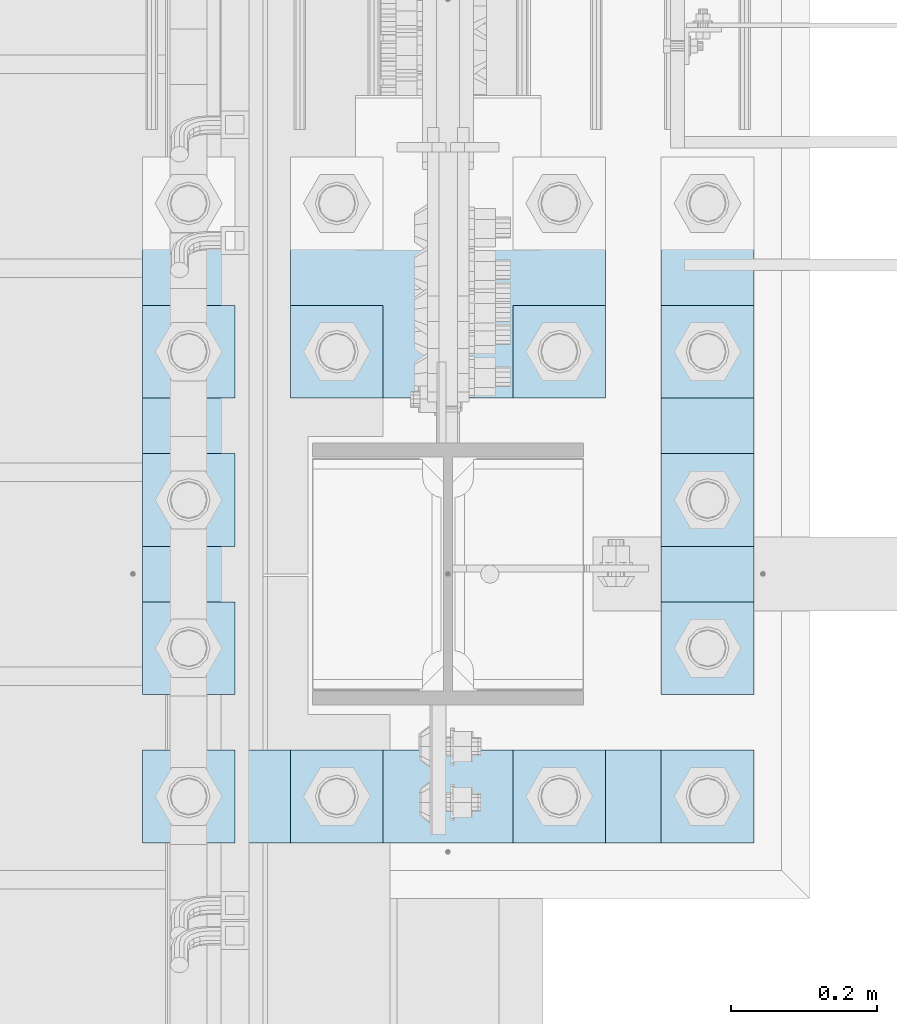
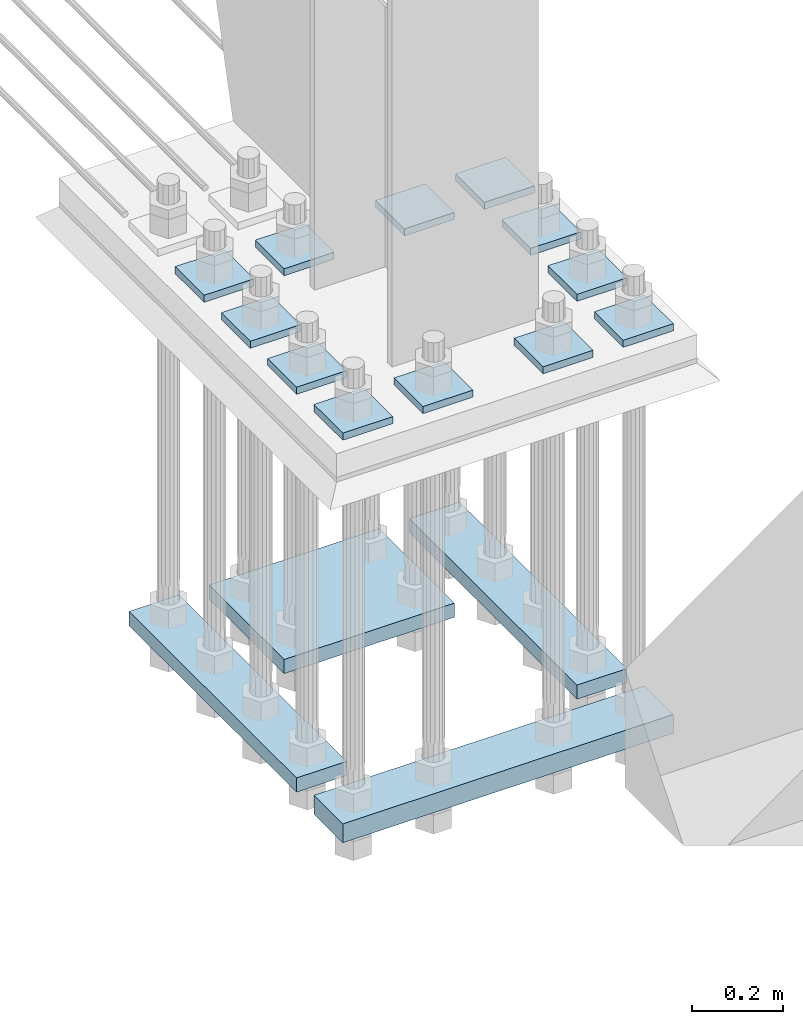
# One storey, part 3121 of 3843: 16 plates, 1 element without a shape of its own.
"""IFC2X3 building model written with IfcOpenShell, lengths in millimetres."""

from ifc_helpers import new_model, si_unit, frame, origin_with_axes, place, context, subcontext, project, spatial, faceted_brep, material, type_object, element, aggregate, save


model = new_model("IFC2X3")

# Units and contexts
model_context = context("Model", 3, precision=1e-05, world=origin_with_axes())
body_context = subcontext(model_context, "Body", "Model", "MODEL_VIEW")
ifc_project = project(units=[si_unit("LENGTHUNIT", "METRE", prefix="MILLI"), si_unit("AREAUNIT", "SQUARE_METRE"), si_unit("VOLUMEUNIT", "CUBIC_METRE"), si_unit("MASSUNIT", "GRAM", prefix="KILO"), si_unit("TIMEUNIT", "SECOND"), si_unit("PLANEANGLEUNIT", "RADIAN"), si_unit("SOLIDANGLEUNIT", "STERADIAN"), si_unit("THERMODYNAMICTEMPERATUREUNIT", "DEGREE_CELSIUS"), si_unit("LUMINOUSINTENSITYUNIT", "LUMEN")], contexts=[model_context])

# Site, building, storey
site_placement = place(None, origin_with_axes())
site = spatial("IfcSite", under=ifc_project, at=site_placement, CompositionType="ELEMENT")
building_placement = place(site_placement, origin_with_axes())
building = spatial("IfcBuilding", under=site, at=building_placement, Name="Undefined", CompositionType="ELEMENT")
storey_placement = place(building_placement, origin_with_axes())
storey = spatial("IfcBuildingStorey", under=building, at=storey_placement, Name="Undefined", CompositionType="ELEMENT", Elevation=0.0)

# Assembly, plates
assembly_placement = place(storey_placement, origin_with_axes())
assembly = element("IfcElementAssembly", 1, at=assembly_placement, inside=storey, Name="TEMPLATE", AssemblyPlace="NOTDEFINED", PredefinedType="RIGID_FRAME")
ifc_material = material(Name="STEEL/A572-50")
plate_type_1 = type_object("IfcPlateType", PredefinedType="NOTDEFINED")
plate_1_placement = place(assembly_placement, frame((55638.7, 20066.0, 29689.425), z_axis=(-1.0, 0.0, 0.0), x_axis=(0.0, -1.0, 0.0)))
plate_1 = element("IfcPlate", 2, at=plate_1_placement, type_object=plate_type_1, material=ifc_material, Name="Washer Plate", context=body_context, shape_type="Brep", body=[
    faceted_brep([(0.0, -9.52500000000146, 0.0), (0.0, -9.52499999999418, 127.0), (0.0, 9.52499999999418, 127.0), (0.0, 9.52500000000146, 0.0), (127.0, -9.52500000000146, 127.0), (127.0, 9.52500000000146, 127.0), (127.0, -9.52500000000146, 0.0), (127.0, 9.52500000000146, 0.0)], [[[0, 1, 2, 3]], [[1, 4, 5, 2]], [[4, 6, 7, 5]], [[6, 0, 3, 7]], [[5, 7, 3, 2]], [[6, 4, 1, 0]]]),
])
plate_2_placement = place(assembly_placement, frame((55841.9, 20066.0, 29689.425), z_axis=(-1.0, 0.0, 0.0), x_axis=(0.0, -1.0, 0.0)))
plate_2 = element("IfcPlate", 3, at=plate_2_placement, type_object=plate_type_1, material=ifc_material, Name="Washer Plate", context=body_context, shape_type="Brep", body=[
    faceted_brep([(0.0, -9.52500000000146, 0.0), (0.0, -9.52499999999418, 127.0), (0.0, 9.52499999999418, 127.0), (0.0, 9.52500000000146, 0.0), (127.0, -9.52500000000146, 127.0), (127.0, 9.52500000000146, 127.0), (127.0, -9.52500000000146, 0.0), (127.0, 9.52500000000146, 0.0)], [[[0, 1, 2, 3]], [[1, 4, 5, 2]], [[4, 6, 7, 5]], [[6, 0, 3, 7]], [[5, 7, 3, 2]], [[6, 4, 1, 0]]]),
])
plate_3_placement = place(assembly_placement, frame((56146.7, 20066.0, 29689.425), z_axis=(-1.0, 0.0, 0.0), x_axis=(0.0, -1.0, 0.0)))
plate_3 = element("IfcPlate", 4, at=plate_3_placement, type_object=plate_type_1, material=ifc_material, Name="Washer Plate", context=body_context, shape_type="Brep", body=[
    faceted_brep([(0.0, -9.52500000000146, 0.0), (0.0, -9.52499999999418, 127.0), (0.0, 9.52499999999418, 127.0), (0.0, 9.52500000000146, 0.0), (127.0, -9.52500000000146, 127.0), (127.0, 9.52500000000146, 127.0), (127.0, -9.52500000000146, 0.0), (127.0, 9.52500000000146, 0.0)], [[[0, 1, 2, 3]], [[1, 4, 5, 2]], [[4, 6, 7, 5]], [[6, 0, 3, 7]], [[5, 7, 3, 2]], [[6, 4, 1, 0]]]),
])
plate_4_placement = place(assembly_placement, frame((56349.9, 20066.0, 29689.425), z_axis=(-1.0, 0.0, 0.0), x_axis=(0.0, -1.0, 0.0)))
plate_4 = element("IfcPlate", 5, at=plate_4_placement, type_object=plate_type_1, material=ifc_material, Name="Washer Plate", context=body_context, shape_type="Brep", body=[
    faceted_brep([(0.0, -9.52500000000146, 0.0), (0.0, -9.52499999999418, 127.0), (0.0, 9.52499999999418, 127.0), (0.0, 9.52500000000146, 0.0), (127.0, -9.52500000000146, 127.0), (127.0, 9.52500000000146, 127.0), (127.0, -9.52500000000146, 0.0), (127.0, 9.52500000000146, 0.0)], [[[0, 1, 2, 3]], [[1, 4, 5, 2]], [[4, 6, 7, 5]], [[6, 0, 3, 7]], [[5, 7, 3, 2]], [[6, 4, 1, 0]]]),
])
plate_5_placement = place(assembly_placement, frame((55638.7, 20269.2, 29689.425), z_axis=(-1.0, 0.0, 0.0), x_axis=(0.0, -1.0, 0.0)))
plate_5 = element("IfcPlate", 6, at=plate_5_placement, type_object=plate_type_1, material=ifc_material, Name="Washer Plate", context=body_context, shape_type="Brep", body=[
    faceted_brep([(0.0, -9.52500000000146, 0.0), (0.0, -9.52499999999418, 127.0), (0.0, 9.52499999999418, 127.0), (0.0, 9.52500000000146, 0.0), (127.0, -9.52500000000146, 127.0), (127.0, 9.52500000000146, 127.0), (127.0, -9.52500000000146, 0.0), (127.0, 9.52500000000146, 0.0)], [[[0, 1, 2, 3]], [[1, 4, 5, 2]], [[4, 6, 7, 5]], [[6, 0, 3, 7]], [[5, 7, 3, 2]], [[6, 4, 1, 0]]]),
])
plate_6_placement = place(assembly_placement, frame((56349.9, 20269.2, 29689.425), z_axis=(-1.0, 0.0, 0.0), x_axis=(0.0, -1.0, 0.0)))
plate_6 = element("IfcPlate", 7, at=plate_6_placement, type_object=plate_type_1, material=ifc_material, Name="Washer Plate", context=body_context, shape_type="Brep", body=[
    faceted_brep([(0.0, -9.52500000000146, 0.0), (0.0, -9.52499999999418, 127.0), (0.0, 9.52499999999418, 127.0), (0.0, 9.52500000000146, 0.0), (127.0, -9.52500000000146, 127.0), (127.0, 9.52500000000146, 127.0), (127.0, -9.52500000000146, 0.0), (127.0, 9.52500000000146, 0.0)], [[[0, 1, 2, 3]], [[1, 4, 5, 2]], [[4, 6, 7, 5]], [[6, 0, 3, 7]], [[5, 7, 3, 2]], [[6, 4, 1, 0]]]),
])
plate_7_placement = place(assembly_placement, frame((55638.7, 20472.4, 29689.425), z_axis=(-1.0, 0.0, 0.0), x_axis=(0.0, -1.0, 0.0)))
plate_7 = element("IfcPlate", 8, at=plate_7_placement, type_object=plate_type_1, material=ifc_material, Name="Washer Plate", context=body_context, shape_type="Brep", body=[
    faceted_brep([(0.0, -9.52500000000146, 0.0), (0.0, -9.52499999999418, 127.0), (0.0, 9.52499999999418, 127.0), (0.0, 9.52500000000146, 0.0), (127.0, -9.52500000000146, 127.0), (127.0, 9.52500000000146, 127.0), (127.0, -9.52500000000146, 0.0), (127.0, 9.52500000000146, 0.0)], [[[0, 1, 2, 3]], [[1, 4, 5, 2]], [[4, 6, 7, 5]], [[6, 0, 3, 7]], [[5, 7, 3, 2]], [[6, 4, 1, 0]]]),
])
plate_8_placement = place(assembly_placement, frame((56349.9, 20472.4, 29689.425), z_axis=(-1.0, 0.0, 0.0), x_axis=(0.0, -1.0, 0.0)))
plate_8 = element("IfcPlate", 9, at=plate_8_placement, type_object=plate_type_1, material=ifc_material, Name="Washer Plate", context=body_context, shape_type="Brep", body=[
    faceted_brep([(0.0, -9.52500000000146, 0.0), (0.0, -9.52499999999418, 127.0), (0.0, 9.52499999999418, 127.0), (0.0, 9.52500000000146, 0.0), (127.0, -9.52500000000146, 127.0), (127.0, 9.52500000000146, 127.0), (127.0, -9.52500000000146, 0.0), (127.0, 9.52500000000146, 0.0)], [[[0, 1, 2, 3]], [[1, 4, 5, 2]], [[4, 6, 7, 5]], [[6, 0, 3, 7]], [[5, 7, 3, 2]], [[6, 4, 1, 0]]]),
])
plate_9_placement = place(assembly_placement, frame((55638.7, 20675.6, 29689.425), z_axis=(-1.0, 0.0, 0.0), x_axis=(0.0, -1.0, 0.0)))
plate_9 = element("IfcPlate", 10, at=plate_9_placement, type_object=plate_type_1, material=ifc_material, Name="Washer Plate", context=body_context, shape_type="Brep", body=[
    faceted_brep([(0.0, -9.52500000000146, 0.0), (0.0, -9.52499999999418, 127.0), (0.0, 9.52499999999418, 127.0), (0.0, 9.52500000000146, 0.0), (127.0, -9.52500000000146, 127.0), (127.0, 9.52500000000146, 127.0), (127.0, -9.52500000000146, 0.0), (127.0, 9.52500000000146, 0.0)], [[[0, 1, 2, 3]], [[1, 4, 5, 2]], [[4, 6, 7, 5]], [[6, 0, 3, 7]], [[5, 7, 3, 2]], [[6, 4, 1, 0]]]),
])
plate_10_placement = place(assembly_placement, frame((55841.9, 20675.6, 29689.425), z_axis=(-1.0, 0.0, 0.0), x_axis=(0.0, -1.0, 0.0)))
plate_10 = element("IfcPlate", 11, at=plate_10_placement, type_object=plate_type_1, material=ifc_material, Name="Washer Plate", context=body_context, shape_type="Brep", body=[
    faceted_brep([(0.0, -9.52500000000146, 0.0), (0.0, -9.52499999999418, 127.0), (0.0, 9.52499999999418, 127.0), (0.0, 9.52500000000146, 0.0), (127.0, -9.52500000000146, 127.0), (127.0, 9.52500000000146, 127.0), (127.0, -9.52500000000146, 0.0), (127.0, 9.52500000000146, 0.0)], [[[0, 1, 2, 3]], [[1, 4, 5, 2]], [[4, 6, 7, 5]], [[6, 0, 3, 7]], [[5, 7, 3, 2]], [[6, 4, 1, 0]]]),
])
plate_11_placement = place(assembly_placement, frame((56146.7, 20675.6, 29689.425), z_axis=(-1.0, 0.0, 0.0), x_axis=(0.0, -1.0, 0.0)))
plate_11 = element("IfcPlate", 12, at=plate_11_placement, type_object=plate_type_1, material=ifc_material, Name="Washer Plate", context=body_context, shape_type="Brep", body=[
    faceted_brep([(0.0, -9.52500000000146, 0.0), (0.0, -9.52499999999418, 127.0), (0.0, 9.52499999999418, 127.0), (0.0, 9.52500000000146, 0.0), (127.0, -9.52500000000146, 127.0), (127.0, 9.52500000000146, 127.0), (127.0, -9.52500000000146, 0.0), (127.0, 9.52500000000146, 0.0)], [[[0, 1, 2, 3]], [[1, 4, 5, 2]], [[4, 6, 7, 5]], [[6, 0, 3, 7]], [[5, 7, 3, 2]], [[6, 4, 1, 0]]]),
])
plate_12_placement = place(assembly_placement, frame((56349.9, 20675.6, 29689.425), z_axis=(-1.0, 0.0, 0.0), x_axis=(0.0, -1.0, 0.0)))
plate_12 = element("IfcPlate", 13, at=plate_12_placement, type_object=plate_type_1, material=ifc_material, Name="Washer Plate", context=body_context, shape_type="Brep", body=[
    faceted_brep([(0.0, -9.52500000000146, 0.0), (0.0, -9.52499999999418, 127.0), (0.0, 9.52499999999418, 127.0), (0.0, 9.52500000000146, 0.0), (127.0, -9.52500000000146, 127.0), (127.0, 9.52500000000146, 127.0), (127.0, -9.52500000000146, 0.0), (127.0, 9.52500000000146, 0.0)], [[[0, 1, 2, 3]], [[1, 4, 5, 2]], [[4, 6, 7, 5]], [[6, 0, 3, 7]], [[5, 7, 3, 2]], [[6, 4, 1, 0]]]),
])
plate_type_2 = type_object("IfcPlateType", PredefinedType="NOTDEFINED")
plate_13_placement = place(assembly_placement, frame((55511.7, 20142.2, 28632.1499969482), z_axis=(0.0, 1.0, 0.0), x_axis=(1.0, 0.0, 0.0)))
plate_13 = element("IfcPlate", 14, at=plate_13_placement, type_object=plate_type_2, material=ifc_material, Name="PLATE", context=body_context, shape_type="Brep", body=[
    faceted_brep([(0.0, -19.0500000000029, 0.0), (0.0, -19.0499999999993, 736.600036621094), (0.0, 19.0499999999993, 736.600036621094), (0.0, 19.0500000000029, 0.0), (127.0, -19.0499999999993, 736.600036621094), (127.0, 19.0499999999993, 736.600036621094), (127.0, -19.0499999999993, 0.0), (127.0, 19.0499999999993, 0.0)], [[[0, 1, 2, 3]], [[1, 4, 5, 2]], [[4, 6, 7, 5]], [[6, 0, 3, 7]], [[5, 7, 3, 2]], [[6, 4, 1, 0]]]),
])
plate_14_placement = place(assembly_placement, frame((56222.9, 20142.2, 28632.1499969482), z_axis=(0.0, 1.0, 0.0), x_axis=(1.0, 0.0, 0.0)))
plate_14 = element("IfcPlate", 15, at=plate_14_placement, type_object=plate_type_2, material=ifc_material, Name="PLATE", context=body_context, shape_type="Brep", body=[
    faceted_brep([(0.0, -19.0500000000029, 0.0), (0.0, -19.0499999999993, 736.600036621094), (0.0, 19.0499999999993, 736.600036621094), (0.0, 19.0500000000029, 0.0), (127.0, -19.0499999999993, 736.600036621094), (127.0, 19.0499999999993, 736.600036621094), (127.0, -19.0499999999993, 0.0), (127.0, 19.0499999999993, 0.0)], [[[0, 1, 2, 3]], [[1, 4, 5, 2]], [[4, 6, 7, 5]], [[6, 0, 3, 7]], [[5, 7, 3, 2]], [[6, 4, 1, 0]]]),
])
plate_type_3 = type_object("IfcPlateType", PredefinedType="NOTDEFINED")
plate_15_placement = place(assembly_placement, frame((55714.9, 20548.6, 28632.1499969482), z_axis=(0.0, 1.0, 0.0), x_axis=(1.0, 0.0, 0.0)))
plate_15 = element("IfcPlate", 16, at=plate_15_placement, type_object=plate_type_3, material=ifc_material, Name="PLATE", context=body_context, shape_type="Brep", body=[
    faceted_brep([(0.0, -19.0500000000029, 0.0), (0.0, -19.0499999999993, 330.200012207031), (0.0, 19.0499999999993, 330.200012207031), (0.0, 19.0500000000029, 0.0), (431.799957275391, -19.0499999999993, 330.200012207031), (431.799957275391, 19.0499999999993, 330.200012207031), (431.799957275391, -19.0499999999993, 0.0), (431.799957275391, 19.0499999999993, 0.0)], [[[0, 1, 2, 3]], [[1, 4, 5, 2]], [[4, 6, 7, 5]], [[6, 0, 3, 7]], [[5, 7, 3, 2]], [[6, 4, 1, 0]]]),
])
plate_type_4 = type_object("IfcPlateType", PredefinedType="NOTDEFINED")
plate_16_placement = place(assembly_placement, frame((55511.7, 19939.0, 28625.7999969482), z_axis=(0.0, 1.0, 0.0), x_axis=(1.0, 0.0, 0.0)))
plate_16 = element("IfcPlate", 17, at=plate_16_placement, type_object=plate_type_4, material=ifc_material, Name="PLATE", context=body_context, shape_type="Brep", body=[
    faceted_brep([(0.0, -25.3999996185303, 0.0), (-3.69732879335061e-06, -25.4000000000015, 127.000000000004), (-3.69732879335061e-06, 25.4000000000015, 127.000000000004), (0.0, 25.3999996185303, 0.0), (838.200012207286, -25.4000000000015, 127.000000001404), (838.200012207286, 25.4000000000015, 127.000000001404), (838.200012207039, -25.4000000000015, 4.98403096571565e-10), (838.200012207039, 25.4000000000015, 4.98403096571565e-10)], [[[0, 1, 2, 3]], [[1, 4, 5, 2]], [[4, 6, 7, 5]], [[6, 0, 3, 7]], [[5, 7, 3, 2]], [[6, 4, 1, 0]]]),
])
aggregate(assembly, [plate_1, plate_16, plate_15, plate_13, plate_14, plate_2, plate_3, plate_4, plate_5, plate_6, plate_7, plate_8, plate_9, plate_10, plate_11, plate_12])

save(model, "model.ifc")
